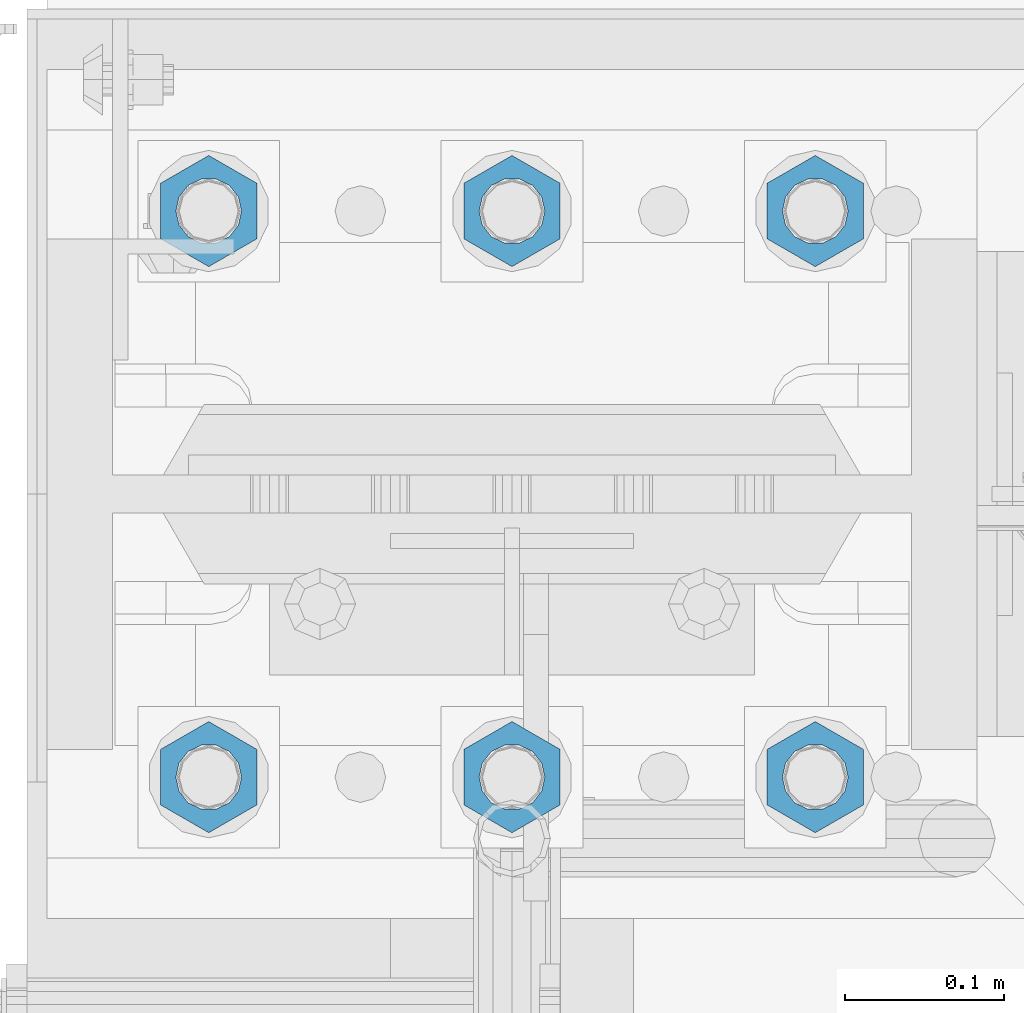
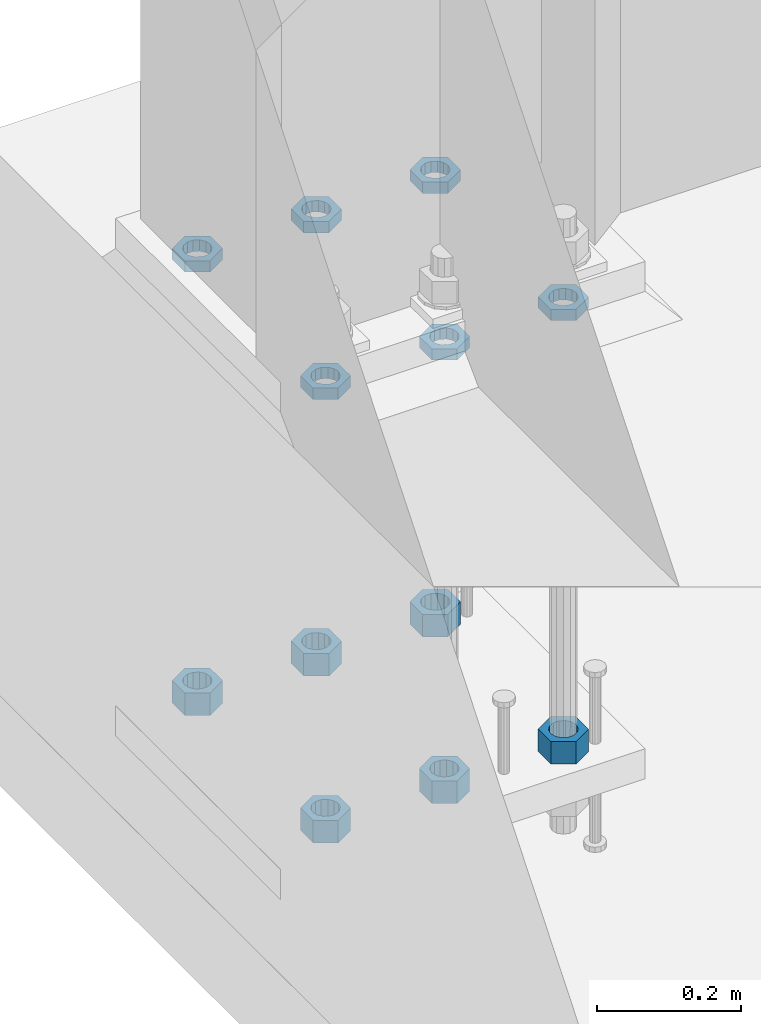
# One storey, part 1395 of 1876: 12 beams, 1 element without a shape of its own.
"""IFC2X3 building model written with IfcOpenShell, lengths in millimetres."""

from ifc_helpers import new_model, si_unit, frame, origin_with_axes, place, context, subcontext, project, spatial, faceted_brep, material, type_object, element, aggregate, save


model = new_model("IFC2X3")

# Units and contexts
model_context = context("Model", 3, precision=1e-05, world=origin_with_axes())
body_context = subcontext(model_context, "Body", "Model", "MODEL_VIEW")
ifc_project = project(units=[si_unit("LENGTHUNIT", "METRE", prefix="MILLI"), si_unit("AREAUNIT", "SQUARE_METRE"), si_unit("VOLUMEUNIT", "CUBIC_METRE"), si_unit("MASSUNIT", "GRAM", prefix="KILO"), si_unit("TIMEUNIT", "SECOND"), si_unit("PLANEANGLEUNIT", "RADIAN"), si_unit("SOLIDANGLEUNIT", "STERADIAN"), si_unit("THERMODYNAMICTEMPERATUREUNIT", "DEGREE_CELSIUS"), si_unit("LUMINOUSINTENSITYUNIT", "LUMEN")], contexts=[model_context])

# Site, building, storey
site_placement = place(None, origin_with_axes())
site = spatial("IfcSite", under=ifc_project, at=site_placement, CompositionType="ELEMENT")
building_placement = place(site_placement, origin_with_axes())
building = spatial("IfcBuilding", under=site, at=building_placement, Name="Undefined", CompositionType="ELEMENT")
storey_placement = place(building_placement, origin_with_axes())
storey = spatial("IfcBuildingStorey", under=building, at=storey_placement, Name="Undefined", CompositionType="ELEMENT", Elevation=0.0)

# Assembly, beams
assembly_placement = place(storey_placement, origin_with_axes())
assembly = element("IfcElementAssembly", 1, at=assembly_placement, inside=storey, Name="TEMPLATE", AssemblyPlace="NOTDEFINED", PredefinedType="RIGID_FRAME")
ifc_material = material(Name="STEEL/A563")
beam_type_1 = type_object("IfcBeamType", Name="1-1/2_DIA. HALF_NUT", PredefinedType="NOTDEFINED")
beam_1_placement = place(assembly_placement, frame((-190.5, 13893.8, 33.3375), z_axis=(-1.0, 0.0, 0.0), x_axis=(0.0, 0.0, -1.0)))
beam_1 = element("IfcBeam", 2, at=beam_1_placement, type_object=beam_type_1, material=ifc_material, Name="NUT", ObjectType="1-1/2_DIA. HALF_NUT", context=body_context, shape_type="Brep", body=[
    faceted_brep([(0.0, -34.9199981689453, 0.0), (0.0, -17.4599990844727, -30.25), (19.0499999999999, -17.4599990844727, -30.25), (19.0499999999999, -34.9199981689453, 0.0), (0.0, 17.4599990844727, -30.25), (19.0499999999999, 17.4599990844727, -30.25), (0.0, 34.9199981689453, 0.0), (19.0499999999999, 34.9199981689453, 0.0), (0.0, 17.4599990844727, 30.25), (19.0499999999999, 17.4599990844727, 30.25), (0.0, -17.4599990844727, 30.25), (19.0499999999999, -17.4599990844727, 30.25), (0.0, 0.0, 20.6399993896484), (0.0, 8.95536011056538, 18.5959968835978), (19.0499999999999, 8.95536011056538, 18.5959968835978), (19.0499999999999, 0.0, 20.6399993896484), (0.0, 16.1370013209489, 12.8688291298158), (19.0499999999999, 16.1370013209489, 12.8688291298158), (0.0, 20.1225115123834, 4.59283194104228), (19.0499999999999, 20.1225115123834, 4.59283194104228), (0.0, 20.1225115123834, -4.59283194104228), (19.0499999999999, 20.1225115123834, -4.59283194104228), (0.0, 16.1370013209489, -12.8688291298167), (19.0499999999999, 16.1370013209489, -12.8688291298167), (0.0, 8.95536011056538, -18.5959968835978), (19.0499999999999, 8.95536011056538, -18.5959968835978), (0.0, 0.0, -20.6399993896484), (19.0499999999999, 0.0, -20.6399993896484), (0.0, -8.95536011056538, -18.5959968835978), (19.0499999999999, -8.95536011056538, -18.5959968835978), (0.0, -16.1370013209489, -12.8688291298158), (19.0499999999999, -16.1370013209489, -12.8688291298158), (0.0, -20.1225115123834, -4.59283194104228), (19.0499999999999, -20.1225115123834, -4.59283194104228), (0.0, -20.1225115123834, 4.59283194104228), (19.0499999999999, -20.1225115123834, 4.59283194104228), (0.0, -16.1370013209489, 12.8688291298167), (19.0499999999999, -16.1370013209489, 12.8688291298167), (0.0, -8.95536011056538, 18.5959968835978), (19.0499999999999, -8.95536011056538, 18.5959968835978)], [[[0, 1, 2, 3]], [[1, 4, 5, 2]], [[4, 6, 7, 5]], [[6, 8, 9, 7]], [[8, 10, 11, 9]], [[10, 0, 3, 11]], [[12, 13, 14, 15]], [[13, 16, 17, 14]], [[16, 18, 19, 17]], [[18, 20, 21, 19]], [[20, 22, 23, 21]], [[22, 24, 25, 23]], [[24, 26, 27, 25]], [[26, 28, 29, 27]], [[28, 30, 31, 29]], [[30, 32, 33, 31]], [[32, 34, 35, 33]], [[34, 36, 37, 35]], [[36, 38, 39, 37]], [[38, 12, 15, 39]], [[5, 7, 9, 11, 3, 2], [17, 19, 21, 23, 25, 27, 29, 31, 33, 35, 37, 39, 15, 14]], [[10, 8, 6, 4, 1, 0], [38, 36, 34, 32, 30, 28, 26, 24, 22, 20, 18, 16, 13, 12]]]),
])
beam_2_placement = place(assembly_placement, frame((-2.8421709430404e-14, 13893.8, 33.3375), z_axis=(-1.0, 0.0, 0.0), x_axis=(0.0, 0.0, -1.0)))
beam_2 = element("IfcBeam", 3, at=beam_2_placement, type_object=beam_type_1, material=ifc_material, Name="NUT", ObjectType="1-1/2_DIA. HALF_NUT", context=body_context, shape_type="Brep", body=[
    faceted_brep([(0.0, -34.9199981689453, 0.0), (0.0, -17.4599990844727, -30.25), (19.0499999999999, -17.4599990844727, -30.25), (19.0499999999999, -34.9199981689453, 0.0), (0.0, 17.4599990844727, -30.25), (19.0499999999999, 17.4599990844727, -30.25), (0.0, 34.9199981689453, 0.0), (19.0499999999999, 34.9199981689453, 0.0), (0.0, 17.4599990844727, 30.25), (19.0499999999999, 17.4599990844727, 30.25), (0.0, -17.4599990844727, 30.25), (19.0499999999999, -17.4599990844727, 30.25), (0.0, 0.0, 20.6399993896484), (0.0, 8.95536011056538, 18.5959968835978), (19.0499999999999, 8.95536011056538, 18.5959968835978), (19.0499999999999, 0.0, 20.6399993896484), (0.0, 16.1370013209489, 12.8688291298158), (19.0499999999999, 16.1370013209489, 12.8688291298158), (0.0, 20.1225115123834, 4.59283194104228), (19.0499999999999, 20.1225115123834, 4.59283194104228), (0.0, 20.1225115123834, -4.59283194104228), (19.0499999999999, 20.1225115123834, -4.59283194104228), (0.0, 16.1370013209489, -12.8688291298167), (19.0499999999999, 16.1370013209489, -12.8688291298167), (0.0, 8.95536011056538, -18.5959968835978), (19.0499999999999, 8.95536011056538, -18.5959968835978), (0.0, 0.0, -20.6399993896484), (19.0499999999999, 0.0, -20.6399993896484), (0.0, -8.95536011056538, -18.5959968835978), (19.0499999999999, -8.95536011056538, -18.5959968835978), (0.0, -16.1370013209489, -12.8688291298158), (19.0499999999999, -16.1370013209489, -12.8688291298158), (0.0, -20.1225115123834, -4.59283194104228), (19.0499999999999, -20.1225115123834, -4.59283194104228), (0.0, -20.1225115123834, 4.59283194104228), (19.0499999999999, -20.1225115123834, 4.59283194104228), (0.0, -16.1370013209489, 12.8688291298167), (19.0499999999999, -16.1370013209489, 12.8688291298167), (0.0, -8.95536011056538, 18.5959968835978), (19.0499999999999, -8.95536011056538, 18.5959968835978)], [[[0, 1, 2, 3]], [[1, 4, 5, 2]], [[4, 6, 7, 5]], [[6, 8, 9, 7]], [[8, 10, 11, 9]], [[10, 0, 3, 11]], [[12, 13, 14, 15]], [[13, 16, 17, 14]], [[16, 18, 19, 17]], [[18, 20, 21, 19]], [[20, 22, 23, 21]], [[22, 24, 25, 23]], [[24, 26, 27, 25]], [[26, 28, 29, 27]], [[28, 30, 31, 29]], [[30, 32, 33, 31]], [[32, 34, 35, 33]], [[34, 36, 37, 35]], [[36, 38, 39, 37]], [[38, 12, 15, 39]], [[5, 7, 9, 11, 3, 2], [17, 19, 21, 23, 25, 27, 29, 31, 33, 35, 37, 39, 15, 14]], [[10, 8, 6, 4, 1, 0], [38, 36, 34, 32, 30, 28, 26, 24, 22, 20, 18, 16, 13, 12]]]),
])
beam_3_placement = place(assembly_placement, frame((190.5, 13893.8, 33.3375), z_axis=(-1.0, 0.0, 0.0), x_axis=(0.0, 0.0, -1.0)))
beam_3 = element("IfcBeam", 4, at=beam_3_placement, type_object=beam_type_1, material=ifc_material, Name="NUT", ObjectType="1-1/2_DIA. HALF_NUT", context=body_context, shape_type="Brep", body=[
    faceted_brep([(0.0, -34.9199981689453, 0.0), (0.0, -17.4599990844727, -30.25), (19.0499999999999, -17.4599990844727, -30.25), (19.0499999999999, -34.9199981689453, 0.0), (0.0, 17.4599990844727, -30.25), (19.0499999999999, 17.4599990844727, -30.25), (0.0, 34.9199981689453, 0.0), (19.0499999999999, 34.9199981689453, 0.0), (0.0, 17.4599990844727, 30.25), (19.0499999999999, 17.4599990844727, 30.25), (0.0, -17.4599990844727, 30.25), (19.0499999999999, -17.4599990844727, 30.25), (0.0, 0.0, 20.6399993896484), (0.0, 8.95536011056538, 18.5959968835978), (19.0499999999999, 8.95536011056538, 18.5959968835978), (19.0499999999999, 0.0, 20.6399993896484), (0.0, 16.1370013209489, 12.8688291298158), (19.0499999999999, 16.1370013209489, 12.8688291298158), (0.0, 20.1225115123834, 4.59283194104228), (19.0499999999999, 20.1225115123834, 4.59283194104228), (0.0, 20.1225115123834, -4.59283194104228), (19.0499999999999, 20.1225115123834, -4.59283194104228), (0.0, 16.1370013209489, -12.8688291298167), (19.0499999999999, 16.1370013209489, -12.8688291298167), (0.0, 8.95536011056538, -18.5959968835978), (19.0499999999999, 8.95536011056538, -18.5959968835978), (0.0, 0.0, -20.6399993896484), (19.0499999999999, 0.0, -20.6399993896484), (0.0, -8.95536011056538, -18.5959968835978), (19.0499999999999, -8.95536011056538, -18.5959968835978), (0.0, -16.1370013209489, -12.8688291298158), (19.0499999999999, -16.1370013209489, -12.8688291298158), (0.0, -20.1225115123834, -4.59283194104228), (19.0499999999999, -20.1225115123834, -4.59283194104228), (0.0, -20.1225115123834, 4.59283194104228), (19.0499999999999, -20.1225115123834, 4.59283194104228), (0.0, -16.1370013209489, 12.8688291298167), (19.0499999999999, -16.1370013209489, 12.8688291298167), (0.0, -8.95536011056538, 18.5959968835978), (19.0499999999999, -8.95536011056538, 18.5959968835978)], [[[0, 1, 2, 3]], [[1, 4, 5, 2]], [[4, 6, 7, 5]], [[6, 8, 9, 7]], [[8, 10, 11, 9]], [[10, 0, 3, 11]], [[12, 13, 14, 15]], [[13, 16, 17, 14]], [[16, 18, 19, 17]], [[18, 20, 21, 19]], [[20, 22, 23, 21]], [[22, 24, 25, 23]], [[24, 26, 27, 25]], [[26, 28, 29, 27]], [[28, 30, 31, 29]], [[30, 32, 33, 31]], [[32, 34, 35, 33]], [[34, 36, 37, 35]], [[36, 38, 39, 37]], [[38, 12, 15, 39]], [[5, 7, 9, 11, 3, 2], [17, 19, 21, 23, 25, 27, 29, 31, 33, 35, 37, 39, 15, 14]], [[10, 8, 6, 4, 1, 0], [38, 36, 34, 32, 30, 28, 26, 24, 22, 20, 18, 16, 13, 12]]]),
])
beam_4_placement = place(assembly_placement, frame((190.5, 13538.2, 33.3375), z_axis=(1.0, 0.0, 0.0), x_axis=(0.0, 0.0, -1.0)))
beam_4 = element("IfcBeam", 5, at=beam_4_placement, type_object=beam_type_1, material=ifc_material, Name="NUT", ObjectType="1-1/2_DIA. HALF_NUT", context=body_context, shape_type="Brep", body=[
    faceted_brep([(0.0, -34.9199981689453, 0.0), (0.0, -17.4599990844727, -30.25), (19.0499999999999, -17.4599990844727, -30.25), (19.0499999999999, -34.9199981689453, 0.0), (0.0, 17.4599990844727, -30.25), (19.0499999999999, 17.4599990844727, -30.25), (0.0, 34.9199981689453, 0.0), (19.0499999999999, 34.9199981689453, 0.0), (0.0, 17.4599990844727, 30.25), (19.0499999999999, 17.4599990844727, 30.25), (0.0, -17.4599990844727, 30.25), (19.0499999999999, -17.4599990844727, 30.25), (0.0, 0.0, 20.6399993896484), (0.0, 8.95536011056538, 18.5959968835978), (19.0499999999999, 8.95536011056538, 18.5959968835978), (19.0499999999999, 0.0, 20.6399993896484), (0.0, 16.1370013209489, 12.8688291298158), (19.0499999999999, 16.1370013209489, 12.8688291298158), (0.0, 20.1225115123834, 4.59283194104228), (19.0499999999999, 20.1225115123834, 4.59283194104228), (0.0, 20.1225115123834, -4.59283194104228), (19.0499999999999, 20.1225115123834, -4.59283194104228), (0.0, 16.1370013209489, -12.8688291298167), (19.0499999999999, 16.1370013209489, -12.8688291298167), (0.0, 8.95536011056538, -18.5959968835978), (19.0499999999999, 8.95536011056538, -18.5959968835978), (0.0, 0.0, -20.6399993896484), (19.0499999999999, 0.0, -20.6399993896484), (0.0, -8.95536011056538, -18.5959968835978), (19.0499999999999, -8.95536011056538, -18.5959968835978), (0.0, -16.1370013209489, -12.8688291298158), (19.0499999999999, -16.1370013209489, -12.8688291298158), (0.0, -20.1225115123834, -4.59283194104228), (19.0499999999999, -20.1225115123834, -4.59283194104228), (0.0, -20.1225115123834, 4.59283194104228), (19.0499999999999, -20.1225115123834, 4.59283194104228), (0.0, -16.1370013209489, 12.8688291298167), (19.0499999999999, -16.1370013209489, 12.8688291298167), (0.0, -8.95536011056538, 18.5959968835978), (19.0499999999999, -8.95536011056538, 18.5959968835978)], [[[0, 1, 2, 3]], [[1, 4, 5, 2]], [[4, 6, 7, 5]], [[6, 8, 9, 7]], [[8, 10, 11, 9]], [[10, 0, 3, 11]], [[12, 13, 14, 15]], [[13, 16, 17, 14]], [[16, 18, 19, 17]], [[18, 20, 21, 19]], [[20, 22, 23, 21]], [[22, 24, 25, 23]], [[24, 26, 27, 25]], [[26, 28, 29, 27]], [[28, 30, 31, 29]], [[30, 32, 33, 31]], [[32, 34, 35, 33]], [[34, 36, 37, 35]], [[36, 38, 39, 37]], [[38, 12, 15, 39]], [[5, 7, 9, 11, 3, 2], [17, 19, 21, 23, 25, 27, 29, 31, 33, 35, 37, 39, 15, 14]], [[10, 8, 6, 4, 1, 0], [38, 36, 34, 32, 30, 28, 26, 24, 22, 20, 18, 16, 13, 12]]]),
])
beam_5_placement = place(assembly_placement, frame((-2.8421709430404e-14, 13538.2, 33.3375), z_axis=(1.0, 0.0, 0.0), x_axis=(0.0, 0.0, -1.0)))
beam_5 = element("IfcBeam", 6, at=beam_5_placement, type_object=beam_type_1, material=ifc_material, Name="NUT", ObjectType="1-1/2_DIA. HALF_NUT", context=body_context, shape_type="Brep", body=[
    faceted_brep([(0.0, -34.9199981689453, 0.0), (0.0, -17.4599990844727, -30.25), (19.0499999999999, -17.4599990844727, -30.25), (19.0499999999999, -34.9199981689453, 0.0), (0.0, 17.4599990844727, -30.25), (19.0499999999999, 17.4599990844727, -30.25), (0.0, 34.9199981689453, 0.0), (19.0499999999999, 34.9199981689453, 0.0), (0.0, 17.4599990844727, 30.25), (19.0499999999999, 17.4599990844727, 30.25), (0.0, -17.4599990844727, 30.25), (19.0499999999999, -17.4599990844727, 30.25), (0.0, 0.0, 20.6399993896484), (0.0, 8.95536011056538, 18.5959968835978), (19.0499999999999, 8.95536011056538, 18.5959968835978), (19.0499999999999, 0.0, 20.6399993896484), (0.0, 16.1370013209489, 12.8688291298158), (19.0499999999999, 16.1370013209489, 12.8688291298158), (0.0, 20.1225115123834, 4.59283194104228), (19.0499999999999, 20.1225115123834, 4.59283194104228), (0.0, 20.1225115123834, -4.59283194104228), (19.0499999999999, 20.1225115123834, -4.59283194104228), (0.0, 16.1370013209489, -12.8688291298167), (19.0499999999999, 16.1370013209489, -12.8688291298167), (0.0, 8.95536011056538, -18.5959968835978), (19.0499999999999, 8.95536011056538, -18.5959968835978), (0.0, 0.0, -20.6399993896484), (19.0499999999999, 0.0, -20.6399993896484), (0.0, -8.95536011056538, -18.5959968835978), (19.0499999999999, -8.95536011056538, -18.5959968835978), (0.0, -16.1370013209489, -12.8688291298158), (19.0499999999999, -16.1370013209489, -12.8688291298158), (0.0, -20.1225115123834, -4.59283194104228), (19.0499999999999, -20.1225115123834, -4.59283194104228), (0.0, -20.1225115123834, 4.59283194104228), (19.0499999999999, -20.1225115123834, 4.59283194104228), (0.0, -16.1370013209489, 12.8688291298167), (19.0499999999999, -16.1370013209489, 12.8688291298167), (0.0, -8.95536011056538, 18.5959968835978), (19.0499999999999, -8.95536011056538, 18.5959968835978)], [[[0, 1, 2, 3]], [[1, 4, 5, 2]], [[4, 6, 7, 5]], [[6, 8, 9, 7]], [[8, 10, 11, 9]], [[10, 0, 3, 11]], [[12, 13, 14, 15]], [[13, 16, 17, 14]], [[16, 18, 19, 17]], [[18, 20, 21, 19]], [[20, 22, 23, 21]], [[22, 24, 25, 23]], [[24, 26, 27, 25]], [[26, 28, 29, 27]], [[28, 30, 31, 29]], [[30, 32, 33, 31]], [[32, 34, 35, 33]], [[34, 36, 37, 35]], [[36, 38, 39, 37]], [[38, 12, 15, 39]], [[5, 7, 9, 11, 3, 2], [17, 19, 21, 23, 25, 27, 29, 31, 33, 35, 37, 39, 15, 14]], [[10, 8, 6, 4, 1, 0], [38, 36, 34, 32, 30, 28, 26, 24, 22, 20, 18, 16, 13, 12]]]),
])
beam_6_placement = place(assembly_placement, frame((-190.5, 13538.2, 33.3375), z_axis=(1.0, 0.0, 0.0), x_axis=(0.0, 0.0, -1.0)))
beam_6 = element("IfcBeam", 7, at=beam_6_placement, type_object=beam_type_1, material=ifc_material, Name="NUT", ObjectType="1-1/2_DIA. HALF_NUT", context=body_context, shape_type="Brep", body=[
    faceted_brep([(0.0, -34.9199981689453, 0.0), (0.0, -17.4599990844727, -30.25), (19.0499999999999, -17.4599990844727, -30.25), (19.0499999999999, -34.9199981689453, 0.0), (0.0, 17.4599990844727, -30.25), (19.0499999999999, 17.4599990844727, -30.25), (0.0, 34.9199981689453, 0.0), (19.0499999999999, 34.9199981689453, 0.0), (0.0, 17.4599990844727, 30.25), (19.0499999999999, 17.4599990844727, 30.25), (0.0, -17.4599990844727, 30.25), (19.0499999999999, -17.4599990844727, 30.25), (0.0, 0.0, 20.6399993896484), (0.0, 8.95536011056538, 18.5959968835978), (19.0499999999999, 8.95536011056538, 18.5959968835978), (19.0499999999999, 0.0, 20.6399993896484), (0.0, 16.1370013209489, 12.8688291298158), (19.0499999999999, 16.1370013209489, 12.8688291298158), (0.0, 20.1225115123834, 4.59283194104228), (19.0499999999999, 20.1225115123834, 4.59283194104228), (0.0, 20.1225115123834, -4.59283194104228), (19.0499999999999, 20.1225115123834, -4.59283194104228), (0.0, 16.1370013209489, -12.8688291298167), (19.0499999999999, 16.1370013209489, -12.8688291298167), (0.0, 8.95536011056538, -18.5959968835978), (19.0499999999999, 8.95536011056538, -18.5959968835978), (0.0, 0.0, -20.6399993896484), (19.0499999999999, 0.0, -20.6399993896484), (0.0, -8.95536011056538, -18.5959968835978), (19.0499999999999, -8.95536011056538, -18.5959968835978), (0.0, -16.1370013209489, -12.8688291298158), (19.0499999999999, -16.1370013209489, -12.8688291298158), (0.0, -20.1225115123834, -4.59283194104228), (19.0499999999999, -20.1225115123834, -4.59283194104228), (0.0, -20.1225115123834, 4.59283194104228), (19.0499999999999, -20.1225115123834, 4.59283194104228), (0.0, -16.1370013209489, 12.8688291298167), (19.0499999999999, -16.1370013209489, 12.8688291298167), (0.0, -8.95536011056538, 18.5959968835978), (19.0499999999999, -8.95536011056538, 18.5959968835978)], [[[0, 1, 2, 3]], [[1, 4, 5, 2]], [[4, 6, 7, 5]], [[6, 8, 9, 7]], [[8, 10, 11, 9]], [[10, 0, 3, 11]], [[12, 13, 14, 15]], [[13, 16, 17, 14]], [[16, 18, 19, 17]], [[18, 20, 21, 19]], [[20, 22, 23, 21]], [[22, 24, 25, 23]], [[24, 26, 27, 25]], [[26, 28, 29, 27]], [[28, 30, 31, 29]], [[30, 32, 33, 31]], [[32, 34, 35, 33]], [[34, 36, 37, 35]], [[36, 38, 39, 37]], [[38, 12, 15, 39]], [[5, 7, 9, 11, 3, 2], [17, 19, 21, 23, 25, 27, 29, 31, 33, 35, 37, 39, 15, 14]], [[10, 8, 6, 4, 1, 0], [38, 36, 34, 32, 30, 28, 26, 24, 22, 20, 18, 16, 13, 12]]]),
])
beam_type_2 = type_object("IfcBeamType", Name="1-1/2_HEAVY_HEX_NUT", PredefinedType="NOTDEFINED")
beam_7_placement = place(assembly_placement, frame((190.5, 13538.2, -698.5), z_axis=(1.0, 0.0, 0.0), x_axis=(0.0, 0.0, -1.0)))
beam_7 = element("IfcBeam", 8, at=beam_7_placement, type_object=beam_type_2, material=ifc_material, Name="NUT", ObjectType="1-1/2_HEAVY_HEX_NUT", context=body_context, shape_type="Brep", body=[
    faceted_brep([(0.0, -34.9199981689453, 0.0), (0.0, -17.4599990844727, -30.25), (38.1, -17.4599990844727, -30.25), (38.1, -34.9199981689453, 0.0), (0.0, 17.4599990844727, -30.25), (38.1, 17.4599990844727, -30.25), (0.0, 34.9199981689453, 0.0), (38.1, 34.9199981689453, 0.0), (0.0, 17.4599990844727, 30.25), (38.1, 17.4599990844727, 30.25), (0.0, -17.4599990844727, 30.25), (38.1, -17.4599990844727, 30.25), (0.0, 0.0, 20.6399993896484), (0.0, 8.95536011056538, 18.5959968835978), (38.1, 8.95536011056447, 18.595996883598), (38.1, 0.0, 20.6399993896484), (0.0, 16.1370013209489, 12.8688291298158), (38.1, 16.137001320948, 12.8688291298162), (0.0, 20.1225115123834, 4.59283194104228), (38.1, 20.1225115123843, 4.59283194104222), (0.0, 20.1225115123834, -4.59283194104228), (38.1, 20.1225115123843, -4.59283194104239), (0.0, 16.1370013209489, -12.8688291298167), (38.1, 16.137001320948, -12.8688291298163), (0.0, 8.95536011056538, -18.5959968835978), (38.1, 8.95536011056447, -18.5959968835982), (0.0, 0.0, -20.6399993896484), (38.1, 0.0, -20.6399993896484), (0.0, -8.95536011056538, -18.5959968835978), (38.1, -8.95536011056447, -18.595996883598), (0.0, -16.1370013209489, -12.8688291298158), (38.1, -16.137001320948, -12.8688291298162), (0.0, -20.1225115123834, -4.59283194104228), (38.1, -20.1225115123843, -4.59283194104222), (0.0, -20.1225115123834, 4.59283194104228), (38.1, -20.1225115123843, 4.59283194104239), (0.0, -16.1370013209489, 12.8688291298167), (38.1, -16.137001320948, 12.8688291298163), (0.0, -8.95536011056538, 18.5959968835978), (38.1, -8.95536011056447, 18.5959968835982)], [[[0, 1, 2, 3]], [[1, 4, 5, 2]], [[4, 6, 7, 5]], [[6, 8, 9, 7]], [[8, 10, 11, 9]], [[10, 0, 3, 11]], [[12, 13, 14, 15]], [[13, 16, 17, 14]], [[16, 18, 19, 17]], [[18, 20, 21, 19]], [[20, 22, 23, 21]], [[22, 24, 25, 23]], [[24, 26, 27, 25]], [[26, 28, 29, 27]], [[28, 30, 31, 29]], [[30, 32, 33, 31]], [[32, 34, 35, 33]], [[34, 36, 37, 35]], [[36, 38, 39, 37]], [[38, 12, 15, 39]], [[5, 7, 9, 11, 3, 2], [17, 19, 21, 23, 25, 27, 29, 31, 33, 35, 37, 39, 15, 14]], [[10, 8, 6, 4, 1, 0], [38, 36, 34, 32, 30, 28, 26, 24, 22, 20, 18, 16, 13, 12]]]),
])
beam_8_placement = place(assembly_placement, frame((190.5, 13893.8, -698.5), z_axis=(-1.0, 0.0, 0.0), x_axis=(0.0, 0.0, -1.0)))
beam_8 = element("IfcBeam", 9, at=beam_8_placement, type_object=beam_type_2, material=ifc_material, Name="NUT", ObjectType="1-1/2_HEAVY_HEX_NUT", context=body_context, shape_type="Brep", body=[
    faceted_brep([(0.0, -34.9199981689453, 0.0), (0.0, -17.4599990844727, -30.25), (38.1, -17.4599990844727, -30.25), (38.1, -34.9199981689453, 0.0), (0.0, 17.4599990844727, -30.25), (38.1, 17.4599990844727, -30.25), (0.0, 34.9199981689453, 0.0), (38.1, 34.9199981689453, 0.0), (0.0, 17.4599990844727, 30.25), (38.1, 17.4599990844727, 30.25), (0.0, -17.4599990844727, 30.25), (38.1, -17.4599990844727, 30.25), (0.0, 0.0, 20.6399993896484), (0.0, 8.95536011056538, 18.5959968835978), (38.1, 8.95536011056447, 18.595996883598), (38.1, 0.0, 20.6399993896484), (0.0, 16.1370013209489, 12.8688291298158), (38.1, 16.137001320948, 12.8688291298162), (0.0, 20.1225115123834, 4.59283194104228), (38.1, 20.1225115123843, 4.59283194104222), (0.0, 20.1225115123834, -4.59283194104228), (38.1, 20.1225115123843, -4.59283194104239), (0.0, 16.1370013209489, -12.8688291298167), (38.1, 16.137001320948, -12.8688291298163), (0.0, 8.95536011056538, -18.5959968835978), (38.1, 8.95536011056447, -18.5959968835982), (0.0, 0.0, -20.6399993896484), (38.1, 0.0, -20.6399993896484), (0.0, -8.95536011056538, -18.5959968835978), (38.1, -8.95536011056447, -18.595996883598), (0.0, -16.1370013209489, -12.8688291298158), (38.1, -16.137001320948, -12.8688291298162), (0.0, -20.1225115123834, -4.59283194104228), (38.1, -20.1225115123843, -4.59283194104222), (0.0, -20.1225115123834, 4.59283194104228), (38.1, -20.1225115123843, 4.59283194104239), (0.0, -16.1370013209489, 12.8688291298167), (38.1, -16.137001320948, 12.8688291298163), (0.0, -8.95536011056538, 18.5959968835978), (38.1, -8.95536011056447, 18.5959968835982)], [[[0, 1, 2, 3]], [[1, 4, 5, 2]], [[4, 6, 7, 5]], [[6, 8, 9, 7]], [[8, 10, 11, 9]], [[10, 0, 3, 11]], [[12, 13, 14, 15]], [[13, 16, 17, 14]], [[16, 18, 19, 17]], [[18, 20, 21, 19]], [[20, 22, 23, 21]], [[22, 24, 25, 23]], [[24, 26, 27, 25]], [[26, 28, 29, 27]], [[28, 30, 31, 29]], [[30, 32, 33, 31]], [[32, 34, 35, 33]], [[34, 36, 37, 35]], [[36, 38, 39, 37]], [[38, 12, 15, 39]], [[5, 7, 9, 11, 3, 2], [17, 19, 21, 23, 25, 27, 29, 31, 33, 35, 37, 39, 15, 14]], [[10, 8, 6, 4, 1, 0], [38, 36, 34, 32, 30, 28, 26, 24, 22, 20, 18, 16, 13, 12]]]),
])
beam_9_placement = place(assembly_placement, frame((-2.8421709430404e-14, 13538.2, -698.5), z_axis=(1.0, 0.0, 0.0), x_axis=(0.0, 0.0, -1.0)))
beam_9 = element("IfcBeam", 10, at=beam_9_placement, type_object=beam_type_2, material=ifc_material, Name="NUT", ObjectType="1-1/2_HEAVY_HEX_NUT", context=body_context, shape_type="Brep", body=[
    faceted_brep([(0.0, -34.9199981689453, 0.0), (0.0, -17.4599990844727, -30.25), (38.1, -17.4599990844727, -30.25), (38.1, -34.9199981689453, 0.0), (0.0, 17.4599990844727, -30.25), (38.1, 17.4599990844727, -30.25), (0.0, 34.9199981689453, 0.0), (38.1, 34.9199981689453, 0.0), (0.0, 17.4599990844727, 30.25), (38.1, 17.4599990844727, 30.25), (0.0, -17.4599990844727, 30.25), (38.1, -17.4599990844727, 30.25), (0.0, 0.0, 20.6399993896484), (0.0, 8.95536011056538, 18.5959968835978), (38.1, 8.95536011056447, 18.595996883598), (38.1, 0.0, 20.6399993896484), (0.0, 16.1370013209489, 12.8688291298158), (38.1, 16.137001320948, 12.8688291298162), (0.0, 20.1225115123834, 4.59283194104228), (38.1, 20.1225115123843, 4.59283194104222), (0.0, 20.1225115123834, -4.59283194104228), (38.1, 20.1225115123843, -4.59283194104239), (0.0, 16.1370013209489, -12.8688291298167), (38.1, 16.137001320948, -12.8688291298163), (0.0, 8.95536011056538, -18.5959968835978), (38.1, 8.95536011056447, -18.5959968835982), (0.0, 0.0, -20.6399993896484), (38.1, 0.0, -20.6399993896484), (0.0, -8.95536011056538, -18.5959968835978), (38.1, -8.95536011056447, -18.595996883598), (0.0, -16.1370013209489, -12.8688291298158), (38.1, -16.137001320948, -12.8688291298162), (0.0, -20.1225115123834, -4.59283194104228), (38.1, -20.1225115123843, -4.59283194104222), (0.0, -20.1225115123834, 4.59283194104228), (38.1, -20.1225115123843, 4.59283194104239), (0.0, -16.1370013209489, 12.8688291298167), (38.1, -16.137001320948, 12.8688291298163), (0.0, -8.95536011056538, 18.5959968835978), (38.1, -8.95536011056447, 18.5959968835982)], [[[0, 1, 2, 3]], [[1, 4, 5, 2]], [[4, 6, 7, 5]], [[6, 8, 9, 7]], [[8, 10, 11, 9]], [[10, 0, 3, 11]], [[12, 13, 14, 15]], [[13, 16, 17, 14]], [[16, 18, 19, 17]], [[18, 20, 21, 19]], [[20, 22, 23, 21]], [[22, 24, 25, 23]], [[24, 26, 27, 25]], [[26, 28, 29, 27]], [[28, 30, 31, 29]], [[30, 32, 33, 31]], [[32, 34, 35, 33]], [[34, 36, 37, 35]], [[36, 38, 39, 37]], [[38, 12, 15, 39]], [[5, 7, 9, 11, 3, 2], [17, 19, 21, 23, 25, 27, 29, 31, 33, 35, 37, 39, 15, 14]], [[10, 8, 6, 4, 1, 0], [38, 36, 34, 32, 30, 28, 26, 24, 22, 20, 18, 16, 13, 12]]]),
])
beam_10_placement = place(assembly_placement, frame((-2.8421709430404e-14, 13893.8, -698.5), z_axis=(-1.0, 0.0, 0.0), x_axis=(0.0, 0.0, -1.0)))
beam_10 = element("IfcBeam", 11, at=beam_10_placement, type_object=beam_type_2, material=ifc_material, Name="NUT", ObjectType="1-1/2_HEAVY_HEX_NUT", context=body_context, shape_type="Brep", body=[
    faceted_brep([(0.0, -34.9199981689453, 0.0), (0.0, -17.4599990844727, -30.25), (38.1, -17.4599990844727, -30.25), (38.1, -34.9199981689453, 0.0), (0.0, 17.4599990844727, -30.25), (38.1, 17.4599990844727, -30.25), (0.0, 34.9199981689453, 0.0), (38.1, 34.9199981689453, 0.0), (0.0, 17.4599990844727, 30.25), (38.1, 17.4599990844727, 30.25), (0.0, -17.4599990844727, 30.25), (38.1, -17.4599990844727, 30.25), (0.0, 0.0, 20.6399993896484), (0.0, 8.95536011056538, 18.5959968835978), (38.1, 8.95536011056447, 18.595996883598), (38.1, 0.0, 20.6399993896484), (0.0, 16.1370013209489, 12.8688291298158), (38.1, 16.137001320948, 12.8688291298162), (0.0, 20.1225115123834, 4.59283194104228), (38.1, 20.1225115123843, 4.59283194104222), (0.0, 20.1225115123834, -4.59283194104228), (38.1, 20.1225115123843, -4.59283194104239), (0.0, 16.1370013209489, -12.8688291298167), (38.1, 16.137001320948, -12.8688291298163), (0.0, 8.95536011056538, -18.5959968835978), (38.1, 8.95536011056447, -18.5959968835982), (0.0, 0.0, -20.6399993896484), (38.1, 0.0, -20.6399993896484), (0.0, -8.95536011056538, -18.5959968835978), (38.1, -8.95536011056447, -18.595996883598), (0.0, -16.1370013209489, -12.8688291298158), (38.1, -16.137001320948, -12.8688291298162), (0.0, -20.1225115123834, -4.59283194104228), (38.1, -20.1225115123843, -4.59283194104222), (0.0, -20.1225115123834, 4.59283194104228), (38.1, -20.1225115123843, 4.59283194104239), (0.0, -16.1370013209489, 12.8688291298167), (38.1, -16.137001320948, 12.8688291298163), (0.0, -8.95536011056538, 18.5959968835978), (38.1, -8.95536011056447, 18.5959968835982)], [[[0, 1, 2, 3]], [[1, 4, 5, 2]], [[4, 6, 7, 5]], [[6, 8, 9, 7]], [[8, 10, 11, 9]], [[10, 0, 3, 11]], [[12, 13, 14, 15]], [[13, 16, 17, 14]], [[16, 18, 19, 17]], [[18, 20, 21, 19]], [[20, 22, 23, 21]], [[22, 24, 25, 23]], [[24, 26, 27, 25]], [[26, 28, 29, 27]], [[28, 30, 31, 29]], [[30, 32, 33, 31]], [[32, 34, 35, 33]], [[34, 36, 37, 35]], [[36, 38, 39, 37]], [[38, 12, 15, 39]], [[5, 7, 9, 11, 3, 2], [17, 19, 21, 23, 25, 27, 29, 31, 33, 35, 37, 39, 15, 14]], [[10, 8, 6, 4, 1, 0], [38, 36, 34, 32, 30, 28, 26, 24, 22, 20, 18, 16, 13, 12]]]),
])
beam_11_placement = place(assembly_placement, frame((-190.5, 13538.2, -698.5), z_axis=(1.0, 0.0, 0.0), x_axis=(0.0, 0.0, -1.0)))
beam_11 = element("IfcBeam", 12, at=beam_11_placement, type_object=beam_type_2, material=ifc_material, Name="NUT", ObjectType="1-1/2_HEAVY_HEX_NUT", context=body_context, shape_type="Brep", body=[
    faceted_brep([(0.0, -34.9199981689453, 0.0), (0.0, -17.4599990844727, -30.25), (38.1, -17.4599990844727, -30.25), (38.1, -34.9199981689453, 0.0), (0.0, 17.4599990844727, -30.25), (38.1, 17.4599990844727, -30.25), (0.0, 34.9199981689453, 0.0), (38.1, 34.9199981689453, 0.0), (0.0, 17.4599990844727, 30.25), (38.1, 17.4599990844727, 30.25), (0.0, -17.4599990844727, 30.25), (38.1, -17.4599990844727, 30.25), (0.0, 0.0, 20.6399993896484), (0.0, 8.95536011056538, 18.5959968835978), (38.1, 8.95536011056447, 18.595996883598), (38.1, 0.0, 20.6399993896484), (0.0, 16.1370013209489, 12.8688291298158), (38.1, 16.137001320948, 12.8688291298162), (0.0, 20.1225115123834, 4.59283194104228), (38.1, 20.1225115123843, 4.59283194104222), (0.0, 20.1225115123834, -4.59283194104228), (38.1, 20.1225115123843, -4.59283194104239), (0.0, 16.1370013209489, -12.8688291298167), (38.1, 16.137001320948, -12.8688291298163), (0.0, 8.95536011056538, -18.5959968835978), (38.1, 8.95536011056447, -18.5959968835982), (0.0, 0.0, -20.6399993896484), (38.1, 0.0, -20.6399993896484), (0.0, -8.95536011056538, -18.5959968835978), (38.1, -8.95536011056447, -18.595996883598), (0.0, -16.1370013209489, -12.8688291298158), (38.1, -16.137001320948, -12.8688291298162), (0.0, -20.1225115123834, -4.59283194104228), (38.1, -20.1225115123843, -4.59283194104222), (0.0, -20.1225115123834, 4.59283194104228), (38.1, -20.1225115123843, 4.59283194104239), (0.0, -16.1370013209489, 12.8688291298167), (38.1, -16.137001320948, 12.8688291298163), (0.0, -8.95536011056538, 18.5959968835978), (38.1, -8.95536011056447, 18.5959968835982)], [[[0, 1, 2, 3]], [[1, 4, 5, 2]], [[4, 6, 7, 5]], [[6, 8, 9, 7]], [[8, 10, 11, 9]], [[10, 0, 3, 11]], [[12, 13, 14, 15]], [[13, 16, 17, 14]], [[16, 18, 19, 17]], [[18, 20, 21, 19]], [[20, 22, 23, 21]], [[22, 24, 25, 23]], [[24, 26, 27, 25]], [[26, 28, 29, 27]], [[28, 30, 31, 29]], [[30, 32, 33, 31]], [[32, 34, 35, 33]], [[34, 36, 37, 35]], [[36, 38, 39, 37]], [[38, 12, 15, 39]], [[5, 7, 9, 11, 3, 2], [17, 19, 21, 23, 25, 27, 29, 31, 33, 35, 37, 39, 15, 14]], [[10, 8, 6, 4, 1, 0], [38, 36, 34, 32, 30, 28, 26, 24, 22, 20, 18, 16, 13, 12]]]),
])
beam_12_placement = place(assembly_placement, frame((-190.5, 13893.8, -698.5), z_axis=(-1.0, 0.0, 0.0), x_axis=(0.0, 0.0, -1.0)))
beam_12 = element("IfcBeam", 13, at=beam_12_placement, type_object=beam_type_2, material=ifc_material, Name="NUT", ObjectType="1-1/2_HEAVY_HEX_NUT", context=body_context, shape_type="Brep", body=[
    faceted_brep([(0.0, -34.9199981689453, 0.0), (0.0, -17.4599990844727, -30.25), (38.1, -17.4599990844727, -30.25), (38.1, -34.9199981689453, 0.0), (0.0, 17.4599990844727, -30.25), (38.1, 17.4599990844727, -30.25), (0.0, 34.9199981689453, 0.0), (38.1, 34.9199981689453, 0.0), (0.0, 17.4599990844727, 30.25), (38.1, 17.4599990844727, 30.25), (0.0, -17.4599990844727, 30.25), (38.1, -17.4599990844727, 30.25), (0.0, 0.0, 20.6399993896484), (0.0, 8.95536011056538, 18.5959968835978), (38.1, 8.95536011056447, 18.595996883598), (38.1, 0.0, 20.6399993896484), (0.0, 16.1370013209489, 12.8688291298158), (38.1, 16.137001320948, 12.8688291298162), (0.0, 20.1225115123834, 4.59283194104228), (38.1, 20.1225115123843, 4.59283194104222), (0.0, 20.1225115123834, -4.59283194104228), (38.1, 20.1225115123843, -4.59283194104239), (0.0, 16.1370013209489, -12.8688291298167), (38.1, 16.137001320948, -12.8688291298163), (0.0, 8.95536011056538, -18.5959968835978), (38.1, 8.95536011056447, -18.5959968835982), (0.0, 0.0, -20.6399993896484), (38.1, 0.0, -20.6399993896484), (0.0, -8.95536011056538, -18.5959968835978), (38.1, -8.95536011056447, -18.595996883598), (0.0, -16.1370013209489, -12.8688291298158), (38.1, -16.137001320948, -12.8688291298162), (0.0, -20.1225115123834, -4.59283194104228), (38.1, -20.1225115123843, -4.59283194104222), (0.0, -20.1225115123834, 4.59283194104228), (38.1, -20.1225115123843, 4.59283194104239), (0.0, -16.1370013209489, 12.8688291298167), (38.1, -16.137001320948, 12.8688291298163), (0.0, -8.95536011056538, 18.5959968835978), (38.1, -8.95536011056447, 18.5959968835982)], [[[0, 1, 2, 3]], [[1, 4, 5, 2]], [[4, 6, 7, 5]], [[6, 8, 9, 7]], [[8, 10, 11, 9]], [[10, 0, 3, 11]], [[12, 13, 14, 15]], [[13, 16, 17, 14]], [[16, 18, 19, 17]], [[18, 20, 21, 19]], [[20, 22, 23, 21]], [[22, 24, 25, 23]], [[24, 26, 27, 25]], [[26, 28, 29, 27]], [[28, 30, 31, 29]], [[30, 32, 33, 31]], [[32, 34, 35, 33]], [[34, 36, 37, 35]], [[36, 38, 39, 37]], [[38, 12, 15, 39]], [[5, 7, 9, 11, 3, 2], [17, 19, 21, 23, 25, 27, 29, 31, 33, 35, 37, 39, 15, 14]], [[10, 8, 6, 4, 1, 0], [38, 36, 34, 32, 30, 28, 26, 24, 22, 20, 18, 16, 13, 12]]]),
])
aggregate(assembly, [beam_1, beam_2, beam_3, beam_4, beam_5, beam_6, beam_7, beam_8, beam_9, beam_10, beam_11, beam_12])

save(model, "model.ifc")
